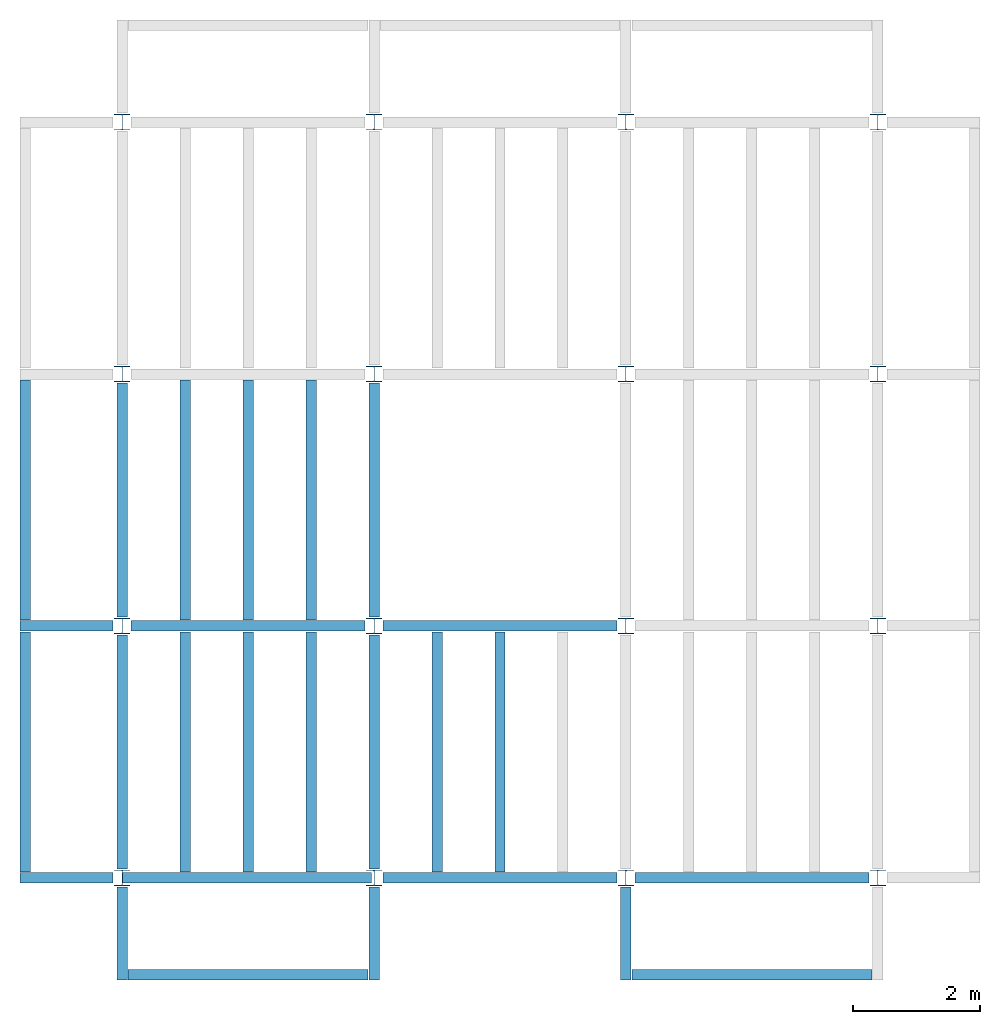
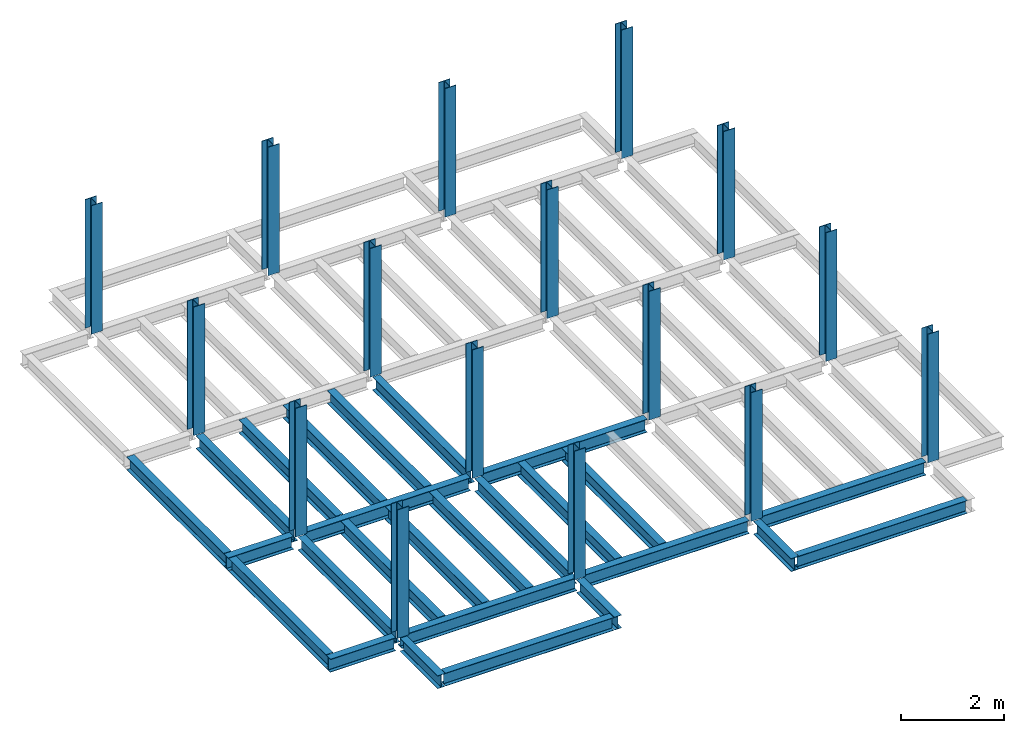
# One storey, part 1 of 3: 26 beams, 16 columns, 3 elements without a shape of their own.
"""IFC4 building model written with IfcOpenShell, lengths in feet."""

from ifc_helpers import new_model, entity, si_unit, converted_unit, derived_unit, direction, frame, origin, origin_2d, place, context, subcontext, project, spatial, line, arc, indexed_curve, i_section, outline, extrude, source, transform, mapped, material, type_object, type_shapes, element, aggregate, save


model = new_model("IFC4")

# Units and contexts
model_context = context("Model", 3, precision=0.0001, world=origin(), true_north=direction((6.123233995736766e-17, 1.0)))
plan_context = context("Plan", 3, precision=0.0001, world=origin(), true_north=direction((6.123233995736766e-17, 1.0)))
body_context = subcontext(model_context, "Body", "Model", "MODEL_VIEW")
ifc_project = project(units=[converted_unit("LENGTHUNIT", "FOOT", entity("IfcLengthMeasure", 0.3048), si_unit("LENGTHUNIT", "METRE"), dimensions=[1, 0, 0, 0, 0, 0, 0]), converted_unit("AREAUNIT", "SQUARE FOOT", entity("IfcAreaMeasure", 0.09290304), si_unit("AREAUNIT", "SQUARE_METRE"), dimensions=[2, 0, 0, 0, 0, 0, 0]), converted_unit("PLANEANGLEUNIT", "DEGREE", entity("IfcPlaneAngleMeasure", 0.017453292519943278), si_unit("PLANEANGLEUNIT", "RADIAN"), dimensions=[0, 0, 0, 0, 0, 0, 0]), converted_unit("VOLUMEUNIT", "CUBIC FOOT", entity("IfcVolumeMeasure", 0.028316846592000004), si_unit("VOLUMEUNIT", "CUBIC_METRE"), dimensions=[3, 0, 0, 0, 0, 0, 0]), si_unit("PRESSUREUNIT", "PASCAL"), derived_unit("MASSDENSITYUNIT", [(si_unit("MASSUNIT", "GRAM", prefix="KILO"), 1), (si_unit("LENGTHUNIT", "METRE"), -3)]), derived_unit("VAPORPERMEABILITYUNIT", [(si_unit("LENGTHUNIT", "METRE"), -1), (si_unit("TIMEUNIT", "SECOND"), 1)]), derived_unit("USERDEFINED", [(si_unit("MASSUNIT", "GRAM", prefix="KILO"), 1), (si_unit("LENGTHUNIT", "METRE"), 3), (si_unit("TIMEUNIT", "SECOND"), -3), (si_unit("ELECTRICCURRENTUNIT", "AMPERE"), -2)]), derived_unit("MODULUSOFELASTICITYUNIT", [(si_unit("MASSUNIT", "GRAM", prefix="KILO"), 1), (si_unit("LENGTHUNIT", "METRE"), -1), (si_unit("TIMEUNIT", "SECOND"), -2)]), derived_unit("THERMALEXPANSIONCOEFFICIENTUNIT", [(si_unit("THERMODYNAMICTEMPERATUREUNIT", "KELVIN"), -1)]), derived_unit("SPECIFICHEATCAPACITYUNIT", [(si_unit("TIMEUNIT", "SECOND"), -2), (si_unit("THERMODYNAMICTEMPERATUREUNIT", "KELVIN"), -1), (si_unit("LENGTHUNIT", "METRE"), 2)]), derived_unit("THERMALCONDUCTANCEUNIT", [(si_unit("MASSUNIT", "GRAM", prefix="KILO"), 1), (si_unit("TIMEUNIT", "SECOND"), -3), (si_unit("THERMODYNAMICTEMPERATUREUNIT", "KELVIN"), -1), (si_unit("LENGTHUNIT", "METRE"), 1)])], contexts=[model_context, plan_context])

# Site, building, storey
site_placement = place(None, origin())
site = spatial("IfcSite", under=ifc_project, at=site_placement, CompositionType="ELEMENT")
building_placement = place(site_placement, origin())
building = spatial("IfcBuilding", under=site, at=building_placement, CompositionType="ELEMENT")
storey_placement = place(building_placement, frame((0.0, 0.0, 119.875)))
storey = spatial("IfcBuildingStorey", under=building, at=storey_placement, Name="STR 13", CompositionType="ELEMENT", Elevation=119.875)

# Columns
ifc_material = material(Name="Steel ASTM A992", Category="Metal")
column_type = type_object("IfcColumnType", Name="W10X49", PredefinedType="COLUMN", material=ifc_material)
shared_shape_1 = source(origin(), body_context, "Body", "SweptSolid", [
    extrude(outline(indexed_curve([(-0.41666666666666663, -0.4166666666666676), (0.41666666666666663, -0.4166666666666676), (0.41666666666666663, -0.3699999999999996), (0.055833333333333846, -0.3699999999999996), (0.02637055078389421, -0.35779611588277277), (0.014166666666666636, -0.32833333333333287), (0.01416666666666665, 0.32833333333333303), (0.026370550783893467, 0.3577961158827727), (0.05583333333333332, 0.3700000000000003), (0.41666666666666663, 0.3700000000000003), (0.41666666666666663, 0.4166666666666656), (-0.41666666666666663, 0.4166666666666656), (-0.41666666666666663, 0.3700000000000003), (-0.05583333333333365, 0.3700000000000003), (-0.02637055078389416, 0.3577961158827734), (-0.014166666666666685, 0.32833333333333387), (-0.014166666666666685, -0.32833333333333264), (-0.026370550783893578, -0.3577961158827721), (-0.055833333333333374, -0.3699999999999996), (-0.41666666666666663, -0.3699999999999996)], segments=[line(1, 2, 3, 4), arc(4, 5, 6), line(6, 7), arc(7, 8, 9), line(9, 10, 11, 12, 13, 14), arc(14, 15, 16), line(16, 17), arc(17, 18, 19), line(19, 20, 1)], self_intersect=False)), frame((0.0, 0.0, 119.875), z_axis=(0.0, 0.0, 1.0), x_axis=(-1.0, 0.0, 0.0)), (0.0, 0.0, 1.0), 10.0),
])
type_shapes(column_type, [shared_shape_1])
for number, where, z_axis, x_axis, name in (
    (1, (0.0, 0.0, -119.875), (0.0, 0.0, 1.0), (-1.0, 0.0, 0.0), "W10X49"),
    (2, (0.0, 13.0, -119.875), (0.0, 0.0, 1.0), (-1.0, 0.0, 0.0), "W10X49"),
    (3, (0.0, 26.0, -119.875), (0.0, 0.0, 1.0), (-1.0, 0.0, 0.0), "W10X49"),
    (4, (0.0, 39.0, -119.875), (0.0, 0.0, 1.0), (-1.0, 0.0, 0.0), "W10X49"),
    (5, (13.0, 0.0, -119.875), (0.0, 0.0, 1.0), (-1.0, 0.0, 0.0), "W10X49"),
    (6, (13.0, 13.0, -119.875), (0.0, 0.0, 1.0), (-1.0, 0.0, 0.0), "W10X49"),
    (7, (13.0, 26.0, -119.875), (0.0, 0.0, 1.0), (-1.0, 0.0, 0.0), "W10X49"),
    (8, (13.0, 39.0, -119.875), (0.0, 0.0, 1.0), (-1.0, 0.0, 0.0), "W10X49"),
    (9, (26.0, 0.0, -119.875), (0.0, 0.0, 1.0), (-1.0, 0.0, 0.0), "W10X49"),
    (10, (26.0, 13.0, -119.875), (0.0, 0.0, 1.0), (-1.0, 0.0, 0.0), "W10X49"),
    (11, (26.0, 26.0, -119.875), (0.0, 0.0, 1.0), (-1.0, 0.0, 0.0), "W10X49"),
    (12, (26.0, 39.0, -119.875), (0.0, 0.0, 1.0), (-1.0, 0.0, 0.0), "W10X49"),
    (13, (39.0, 0.0, -119.875), (0.0, 0.0, 1.0), (-1.0, 0.0, 0.0), "W10X49"),
    (14, (39.0, 13.0, -119.875), (0.0, 0.0, 1.0), (-1.0, 0.0, 0.0), "W10X49"),
    (15, (39.0, 26.0, -119.875), (0.0, 0.0, 1.0), (-1.0, 0.0, 0.0), "W10X49"),
    (16, (39.0, 39.0, -119.875), (0.0, 0.0, 1.0), (-1.0, 0.0, 0.0), "W10X49"),
):
    element("IfcColumn", number, at=place(storey_placement, frame(where, z_axis=z_axis, x_axis=x_axis)), inside=storey, type_object=column_type, material=ifc_material, Name=name, ObjectType="W Shapes-Column:W10X49", PredefinedType="COLUMN", context=body_context, shape_type="MappedRepresentation", body=[
        mapped(shared_shape_1, transform((0.0, 0.0, 0.0), scale=1.0)),
    ])

# Beams
beam_type_1 = type_object("IfcBeamType", Name="W12X26", PredefinedType="JOIST", material=ifc_material)
shared_shape_2 = source(origin(), body_context, "Body", "SweptSolid", [
    extrude(outline(indexed_curve([(-0.27041666666666714, -0.47666666666666574), (-0.27041666666666714, -0.5083333333333351), (0.2704166666666669, -0.5083333333333351), (0.2704166666666669, -0.47666666666666574), (0.03458333333333309, -0.47666666666666574), (0.016905663803669493, -0.46934433619632937), (0.009583333333333202, -0.4516666666666659), (0.0095833333333332, 0.45166666666666705), (0.01690566380366948, 0.4693443361963307), (0.03458333333333325, 0.4766666666666671), (0.2704166666666669, 0.4766666666666671), (0.2704166666666669, 0.5083333333333312), (-0.2704166666666655, 0.5083333333333312), (-0.2704166666666655, 0.4766666666666671), (-0.034583333333333514, 0.47666666666666707), (-0.016905663803669865, 0.46934433619633054), (-0.009583333333333737, 0.45166666666666694), (-0.009583333333333735, -0.4516666666666658), (-0.01690566380367013, -0.4693443361963295), (-0.03458333333333368, -0.47666666666666574)], segments=[line(1, 2, 3, 4, 5), arc(5, 6, 7), line(7, 8), arc(8, 9, 10), line(10, 11, 12, 13, 14, 15), arc(15, 16, 17), line(17, 18), arc(18, 19, 20), line(20, 1)], self_intersect=False)), frame((-6.103346456692914, 0.0, 0.0), z_axis=(-1.0, 0.0, 0.0), x_axis=(0.0, -1.0, 0.0)), (0.0, 0.0, -1.0), 12.083333333333323),
])
type_shapes(beam_type_1, [shared_shape_2])
beam_1_placement = place(storey_placement, frame((6.561679790026266, 13.0, -0.50833333333334)))
element("IfcBeam", 17, at=beam_1_placement, inside=storey, type_object=beam_type_1, material=ifc_material, Name="W12X26", ObjectType="W Shapes:W12X26", PredefinedType="JOIST", context=body_context, shape_type="MappedRepresentation", body=[
    mapped(shared_shape_2, transform((0.0, 0.0, 0.0), scale=1.0)),
])
for number, where, z_axis, x_axis, name in (
    (18, (0.0, 6.561679790026247, -0.50833333333334), (0.0, 0.0, 1.0), (0.0, 1.0, 0.0), "W12X26"),
    (19, (13.0, 6.561679790026204, -0.50833333333334), (0.0, 0.0, 1.0), (0.0, 1.0, 0.0), "W12X26"),
):
    element("IfcBeam", number, at=place(storey_placement, frame(where, z_axis=z_axis, x_axis=x_axis)), inside=storey, type_object=beam_type_1, material=ifc_material, Name=name, ObjectType="W Shapes:W12X26", PredefinedType="JOIST", context=body_context, shape_type="MappedRepresentation", body=[
        mapped(shared_shape_2, transform((0.0, 0.0, 0.0), scale=1.0)),
    ])
beam_type_2 = type_object("IfcBeamType", Name="W12X26", PredefinedType="JOIST", material=ifc_material)
shared_shape_3 = source(origin(), body_context, "Body", "SweptSolid", [
    extrude(outline(indexed_curve([(-0.27041666666666714, -0.47666666666666574), (-0.27041666666666714, -0.5083333333333351), (0.2704166666666669, -0.5083333333333351), (0.2704166666666669, -0.47666666666666574), (0.03458333333333309, -0.47666666666666574), (0.016905663803669493, -0.46934433619632937), (0.009583333333333202, -0.4516666666666659), (0.0095833333333332, 0.45166666666666705), (0.01690566380366948, 0.4693443361963307), (0.03458333333333325, 0.4766666666666671), (0.2704166666666669, 0.4766666666666671), (0.2704166666666669, 0.5083333333333312), (-0.2704166666666655, 0.5083333333333312), (-0.2704166666666655, 0.4766666666666671), (-0.034583333333333514, 0.47666666666666707), (-0.016905663803669865, 0.46934433619633054), (-0.009583333333333737, 0.45166666666666694), (-0.009583333333333735, -0.4516666666666658), (-0.01690566380367013, -0.4693443361963295), (-0.03458333333333368, -0.47666666666666574)], segments=[line(1, 2, 3, 4, 5), arc(5, 6, 7), line(7, 8), arc(8, 9, 10), line(10, 11, 12, 13, 14, 15), arc(15, 16, 17), line(17, 18), arc(18, 19, 20), line(20, 1)], self_intersect=False)), frame((-6.226706036745409, 0.0, 0.0), z_axis=(-1.0, 0.0, 0.0), x_axis=(0.0, -1.0, 0.0)), (0.0, 0.0, -1.0), 12.08333333333333),
])
type_shapes(beam_type_2, [shared_shape_3])
beam_2_placement = place(storey_placement, frame((19.68503937007876, 13.0, -0.50833333333334)))
element("IfcBeam", 20, at=beam_2_placement, inside=storey, type_object=beam_type_2, material=ifc_material, Name="W12X26", ObjectType="W Shapes:W12X26", PredefinedType="JOIST", context=body_context, shape_type="MappedRepresentation", body=[
    mapped(shared_shape_3, transform((0.0, 0.0, 0.0), scale=1.0)),
])
for number, where, z_axis, x_axis, name in (
    (21, (0.0, 19.68503937007874, -0.50833333333334), (0.0, 0.0, 1.0), (0.0, 1.0, 0.0), "W12X26"),
    (22, (13.0, 19.685039370078698, -0.50833333333334), (0.0, 0.0, 1.0), (0.0, 1.0, 0.0), "W12X26"),
):
    element("IfcBeam", number, at=place(storey_placement, frame(where, z_axis=z_axis, x_axis=x_axis)), inside=storey, type_object=beam_type_2, material=ifc_material, Name=name, ObjectType="W Shapes:W12X26", PredefinedType="JOIST", context=body_context, shape_type="MappedRepresentation", body=[
        mapped(shared_shape_3, transform((0.0, 0.0, 0.0), scale=1.0)),
    ])

# Assembly, beams
assembly_1_placement = place(storey_placement, origin())
assembly_1 = element("IfcElementAssembly", 23, at=assembly_1_placement, inside=storey, Name="Structural Framing System", ObjectType="Structural Beam System:Structural Framing System", AssemblyPlace="NOTDEFINED", PredefinedType="BEAM_GRID")
beam_type_3 = type_object("IfcBeamType", Name="W12X26", PredefinedType="JOIST", material=ifc_material)
shared_shape_4 = source(origin(), body_context, "Body", "SweptSolid", [
    extrude(outline(indexed_curve([(-0.27041666666666714, -0.47666666666666574), (-0.27041666666666714, -0.5083333333333351), (0.2704166666666669, -0.5083333333333351), (0.2704166666666669, -0.47666666666666574), (0.03458333333333309, -0.47666666666666574), (0.016905663803669493, -0.46934433619632937), (0.009583333333333202, -0.4516666666666659), (0.0095833333333332, 0.45166666666666705), (0.01690566380366948, 0.4693443361963307), (0.03458333333333325, 0.4766666666666671), (0.2704166666666669, 0.4766666666666671), (0.2704166666666669, 0.5083333333333312), (-0.2704166666666655, 0.5083333333333312), (-0.2704166666666655, 0.4766666666666671), (-0.034583333333333514, 0.47666666666666707), (-0.016905663803669865, 0.46934433619633054), (-0.009583333333333737, 0.45166666666666694), (-0.009583333333333735, -0.4516666666666658), (-0.01690566380367013, -0.4693443361963295), (-0.03458333333333368, -0.47666666666666574)], segments=[line(1, 2, 3, 4, 5), arc(5, 6, 7), line(7, 8), arc(8, 9, 10), line(10, 11, 12, 13, 14, 15), arc(15, 16, 17), line(17, 18), arc(18, 19, 20), line(20, 1)], self_intersect=False)), frame((-6.187916666666566, 0.0, 0.0), z_axis=(-1.0, 0.0, 0.0), x_axis=(0.0, -1.0, 0.0)), (0.0, 0.0, -1.0), 12.375833333333075),
])
type_shapes(beam_type_3, [shared_shape_4])
beam_3_placement = place(assembly_1_placement, frame((3.250000000000031, 6.499999999999844, -0.50833333333334), z_axis=(0.0, 0.0, 1.0), x_axis=(0.0, 1.0, 0.0)))
beam_3 = element("IfcBeam", 24, at=beam_3_placement, type_object=beam_type_3, material=ifc_material, Name="W12X26", ObjectType="W Shapes:W12X26", PredefinedType="JOIST", context=body_context, shape_type="MappedRepresentation", body=[
    mapped(shared_shape_4, transform((0.0, 0.0, 0.0), scale=1.0)),
])
beam_4_placement = place(assembly_1_placement, frame((6.500000000000053, 6.4999999999998455, -0.50833333333334), z_axis=(0.0, 0.0, 1.0), x_axis=(0.0, 1.0, 0.0)))
beam_4 = element("IfcBeam", 25, at=beam_4_placement, type_object=beam_type_3, material=ifc_material, Name="W12X26", ObjectType="W Shapes:W12X26", PredefinedType="JOIST", context=body_context, shape_type="MappedRepresentation", body=[
    mapped(shared_shape_4, transform((0.0, 0.0, 0.0), scale=1.0)),
])
beam_5_placement = place(assembly_1_placement, frame((9.750000000000075, 6.499999999999844, -0.50833333333334), z_axis=(0.0, 0.0, 1.0), x_axis=(0.0, 1.0, 0.0)))
beam_5 = element("IfcBeam", 26, at=beam_5_placement, type_object=beam_type_3, material=ifc_material, Name="W12X26", ObjectType="W Shapes:W12X26", PredefinedType="JOIST", context=body_context, shape_type="MappedRepresentation", body=[
    mapped(shared_shape_4, transform((0.0, 0.0, 0.0), scale=1.0)),
])
aggregate(assembly_1, [beam_3, beam_4, beam_5])

assembly_2_placement = place(storey_placement, origin())
assembly_2 = element("IfcElementAssembly", 27, at=assembly_2_placement, inside=storey, Name="Structural Framing System", ObjectType="Structural Beam System:Structural Framing System", AssemblyPlace="NOTDEFINED", PredefinedType="BEAM_GRID")
beam_6_placement = place(assembly_2_placement, frame((3.2500000000000515, 19.49999999999968, -0.50833333333334), z_axis=(0.0, 0.0, 1.0), x_axis=(0.0, 1.0, 0.0)))
beam_6 = element("IfcBeam", 28, at=beam_6_placement, type_object=beam_type_3, material=ifc_material, Name="W12X26", ObjectType="W Shapes:W12X26", PredefinedType="JOIST", context=body_context, shape_type="MappedRepresentation", body=[
    mapped(shared_shape_4, transform((0.0, 0.0, 0.0), scale=1.0)),
])
beam_7_placement = place(assembly_2_placement, frame((6.500000000000073, 19.499999999999666, -0.50833333333334), z_axis=(0.0, 0.0, 1.0), x_axis=(0.0, 1.0, 0.0)))
beam_7 = element("IfcBeam", 29, at=beam_7_placement, type_object=beam_type_3, material=ifc_material, Name="W12X26", ObjectType="W Shapes:W12X26", PredefinedType="JOIST", context=body_context, shape_type="MappedRepresentation", body=[
    mapped(shared_shape_4, transform((0.0, 0.0, 0.0), scale=1.0)),
])
beam_8_placement = place(assembly_2_placement, frame((9.750000000000094, 19.49999999999966, -0.50833333333334), z_axis=(0.0, 0.0, 1.0), x_axis=(0.0, 1.0, 0.0)))
beam_8 = element("IfcBeam", 30, at=beam_8_placement, type_object=beam_type_3, material=ifc_material, Name="W12X26", ObjectType="W Shapes:W12X26", PredefinedType="JOIST", context=body_context, shape_type="MappedRepresentation", body=[
    mapped(shared_shape_4, transform((0.0, 0.0, 0.0), scale=1.0)),
])
aggregate(assembly_2, [beam_6, beam_7, beam_8])

assembly_3_placement = place(storey_placement, origin())
assembly_3 = element("IfcElementAssembly", 31, at=assembly_3_placement, inside=storey, Name="Structural Framing System", ObjectType="Structural Beam System:Structural Framing System", AssemblyPlace="NOTDEFINED", PredefinedType="BEAM_GRID")
beam_9_placement = place(assembly_3_placement, frame((16.250000000000092, 6.4999999999998, -0.50833333333334), z_axis=(0.0, 0.0, 1.0), x_axis=(0.0, 1.0, 0.0)))
beam_9 = element("IfcBeam", 32, at=beam_9_placement, type_object=beam_type_3, material=ifc_material, Name="W12X26", ObjectType="W Shapes:W12X26", PredefinedType="JOIST", context=body_context, shape_type="MappedRepresentation", body=[
    mapped(shared_shape_4, transform((0.0, 0.0, 0.0), scale=1.0)),
])
beam_10_placement = place(assembly_3_placement, frame((19.5000000000001, 6.4999999999998, -0.50833333333334), z_axis=(0.0, 0.0, 1.0), x_axis=(0.0, 1.0, 0.0)))
beam_10 = element("IfcBeam", 33, at=beam_10_placement, type_object=beam_type_3, material=ifc_material, Name="W12X26", ObjectType="W Shapes:W12X26", PredefinedType="JOIST", context=body_context, shape_type="MappedRepresentation", body=[
    mapped(shared_shape_4, transform((0.0, 0.0, 0.0), scale=1.0)),
])
aggregate(assembly_3, [beam_9, beam_10])

# Beams
for number, where, z_axis, x_axis, name in (
    (34, (-5.0, 6.499999999999858, -0.50833333333334), (0.0, 0.0, 1.0), (0.0, -1.0, 0.0), "W12X26"),
    (35, (-5.0, 19.499999999999705, -0.50833333333334), (0.0, 0.0, 1.0), (0.0, 1.0, 0.0), "W12X26"),
):
    element("IfcBeam", number, at=place(storey_placement, frame(where, z_axis=z_axis, x_axis=x_axis)), inside=storey, type_object=beam_type_3, material=ifc_material, Name=name, ObjectType="W Shapes:W12X26", PredefinedType="JOIST", context=body_context, shape_type="MappedRepresentation", body=[
        mapped(shared_shape_4, transform((0.0, 0.0, 0.0), scale=1.0)),
    ])
beam_type_4 = type_object("IfcBeamType", Name="W12X26", PredefinedType="JOIST", material=ifc_material)
shared_shape_5 = source(origin(), body_context, "Body", "SweptSolid", [
    extrude(outline(indexed_curve([(-0.27041666666666714, -0.47666666666666574), (-0.27041666666666714, -0.5083333333333351), (0.2704166666666669, -0.5083333333333351), (0.2704166666666669, -0.47666666666666574), (0.03458333333333309, -0.47666666666666574), (0.016905663803669493, -0.46934433619632937), (0.009583333333333202, -0.4516666666666659), (0.0095833333333332, 0.45166666666666705), (0.01690566380366948, 0.4693443361963307), (0.03458333333333325, 0.4766666666666671), (0.2704166666666669, 0.4766666666666671), (0.2704166666666669, 0.5083333333333312), (-0.2704166666666655, 0.5083333333333312), (-0.2704166666666655, 0.4766666666666671), (-0.034583333333333514, 0.47666666666666707), (-0.016905663803669865, 0.46934433619633054), (-0.009583333333333737, 0.45166666666666694), (-0.009583333333333735, -0.4516666666666658), (-0.01690566380367013, -0.4693443361963295), (-0.03458333333333368, -0.47666666666666574)], segments=[line(1, 2, 3, 4, 5), arc(5, 6, 7), line(7, 8), arc(8, 9, 10), line(10, 11, 12, 13, 14, 15), arc(15, 16, 17), line(17, 18), arc(18, 19, 20), line(20, 1)], self_intersect=False)), frame((-6.165026246719308, 0.0, 0.0), z_axis=(-1.0, 0.0, 0.0), x_axis=(0.0, -1.0, 0.0)), (0.0, 0.0, -1.0), 12.08333333333334),
])
type_shapes(beam_type_4, [shared_shape_5])
beam_11_placement = place(storey_placement, frame((32.623359580052536, 0.0, -0.50833333333334)))
element("IfcBeam", 36, at=beam_11_placement, inside=storey, type_object=beam_type_4, material=ifc_material, Name="W12X26", ObjectType="W Shapes:W12X26", PredefinedType="JOIST", context=body_context, shape_type="MappedRepresentation", body=[
    mapped(shared_shape_5, transform((0.0, 0.0, 0.0), scale=1.0)),
])
beam_type_5 = type_object("IfcBeamType", Name="W12X26", PredefinedType="JOIST", material=ifc_material)
shared_shape_6 = source(origin(), body_context, "Body", "SweptSolid", [
    extrude(outline(indexed_curve([(-0.27041666666666714, -0.47666666666666574), (-0.27041666666666714, -0.5083333333333351), (0.2704166666666669, -0.5083333333333351), (0.2704166666666669, -0.47666666666666574), (0.03458333333333309, -0.47666666666666574), (0.016905663803669493, -0.46934433619632937), (0.009583333333333202, -0.4516666666666659), (0.0095833333333332, 0.45166666666666705), (0.01690566380366948, 0.4693443361963307), (0.03458333333333325, 0.4766666666666671), (0.2704166666666669, 0.4766666666666671), (0.2704166666666669, 0.5083333333333312), (-0.2704166666666655, 0.5083333333333312), (-0.2704166666666655, 0.4766666666666671), (-0.034583333333333514, 0.47666666666666707), (-0.016905663803669865, 0.46934433619633054), (-0.009583333333333737, 0.45166666666666694), (-0.009583333333333735, -0.4516666666666658), (-0.01690566380367013, -0.4693443361963295), (-0.03458333333333368, -0.47666666666666574)], segments=[line(1, 2, 3, 4, 5), arc(5, 6, 7), line(7, 8), arc(8, 9, 10), line(10, 11, 12, 13, 14, 15), arc(15, 16, 17), line(17, 18), arc(18, 19, 20), line(20, 1)], self_intersect=False)), frame((-6.103346456692852, 0.0, 0.0), z_axis=(-1.0, 0.0, 0.0), x_axis=(0.0, -1.0, 0.0)), (0.0, 0.0, -1.0), 12.083333333333334),
])
type_shapes(beam_type_5, [shared_shape_6])
beam_12_placement = place(storey_placement, frame((19.56167979002627, 0.0, -0.50833333333334)))
element("IfcBeam", 37, at=beam_12_placement, inside=storey, type_object=beam_type_5, material=ifc_material, Name="W12X26", ObjectType="W Shapes:W12X26", PredefinedType="JOIST", context=body_context, shape_type="MappedRepresentation", body=[
    mapped(shared_shape_6, transform((0.0, 0.0, 0.0), scale=1.0)),
])
beam_type_6 = type_object("IfcBeamType", Name="W12X26", PredefinedType="JOIST", material=ifc_material)
shared_shape_7 = source(origin(), body_context, "Body", "SweptSolid", [
    extrude(outline(indexed_curve([(0.47666666666666574, -0.2704166666666672), (0.5083333333333351, -0.2704166666666672), (0.5083333333333351, 0.27041666666666686), (0.47666666666666574, 0.27041666666666686), (0.47666666666666574, 0.03458333333333307), (0.46934433619632937, 0.016905663803669473), (0.4516666666666659, 0.00958333333333318), (-0.45166666666666705, 0.00958333333333318), (-0.4693443361963307, 0.01690566380366946), (-0.4766666666666671, 0.03458333333333323), (-0.4766666666666671, 0.27041666666666686), (-0.5083333333333312, 0.27041666666666686), (-0.5083333333333312, -0.27041666666666553), (-0.4766666666666671, -0.27041666666666553), (-0.47666666666666707, -0.034583333333333535), (-0.46934433619633054, -0.016905663803669885), (-0.45166666666666694, -0.00958333333333376), (0.4516666666666658, -0.009583333333333756), (0.4693443361963295, -0.01690566380367015), (0.47666666666666574, -0.0345833333333337)], segments=[line(1, 2, 3, 4, 5), arc(5, 6, 7), line(7, 8), arc(8, 9, 10), line(10, 11, 12, 13, 14, 15), arc(15, 16, 17), line(17, 18), arc(18, 19, 20), line(20, 1)], self_intersect=False)), frame((-2.0416666666666208, 0.0, 0.0), z_axis=(1.0, 0.0, 0.0), x_axis=(0.0, 0.0, -1.0)), (0.0, 0.0, 1.0), 4.812083333333336),
])
type_shapes(beam_type_6, [shared_shape_7])
for number, where, z_axis, x_axis, name in (
    (38, (26.0, -2.500000000000538, -0.50833333333334), (0.0, 0.0, 1.0), (0.0, -1.0, 0.0), "W12X26"),
    (39, (-2.499999999999853, 13.0, -0.50833333333334), (0.0, 0.0, 1.0), (-1.0, 0.0, 0.0), "W12X26"),
    (40, (-2.4999999999998743, 0.0, -0.50833333333334), (0.0, 0.0, 1.0), (-1.0, 0.0, 0.0), "W12X26"),
):
    element("IfcBeam", number, at=place(storey_placement, frame(where, z_axis=z_axis, x_axis=x_axis)), inside=storey, type_object=beam_type_6, material=ifc_material, Name=name, ObjectType="W Shapes:W12X26", PredefinedType="JOIST", context=body_context, shape_type="MappedRepresentation", body=[
        mapped(shared_shape_7, transform((0.0, 0.0, 0.0), scale=1.0)),
    ])
beam_type_7 = type_object("IfcBeamType", Name="W12X26", PredefinedType="JOIST", material=ifc_material)
shared_shape_8 = source(origin(), body_context, "Body", "SweptSolid", [
    extrude(outline(indexed_curve([(0.47666666666666574, -0.2704166666666672), (0.5083333333333351, -0.2704166666666672), (0.5083333333333351, 0.27041666666666686), (0.47666666666666574, 0.27041666666666686), (0.47666666666666574, 0.03458333333333307), (0.46934433619632937, 0.016905663803669473), (0.4516666666666659, 0.00958333333333318), (-0.45166666666666705, 0.00958333333333318), (-0.4693443361963307, 0.01690566380366946), (-0.4766666666666671, 0.03458333333333323), (-0.4766666666666671, 0.27041666666666686), (-0.5083333333333312, 0.27041666666666686), (-0.5083333333333312, -0.27041666666666553), (-0.4766666666666671, -0.27041666666666553), (-0.47666666666666707, -0.034583333333333535), (-0.46934433619633054, -0.016905663803669885), (-0.45166666666666694, -0.00958333333333376), (0.4516666666666658, -0.009583333333333756), (0.4693443361963295, -0.01690566380367015), (0.47666666666666574, -0.0345833333333337)], segments=[line(1, 2, 3, 4, 5), arc(5, 6, 7), line(7, 8), arc(8, 9, 10), line(10, 11, 12, 13, 14, 15), arc(15, 16, 17), line(17, 18), arc(18, 19, 20), line(20, 1)], self_intersect=False)), frame((-6.187916666666685, 0.0, 0.0), z_axis=(1.0, 0.0, 0.0), x_axis=(0.0, 0.0, -1.0)), (0.0, 0.0, 1.0), 12.375833333333318),
])
type_shapes(beam_type_7, [shared_shape_8])
beam_13_placement = place(storey_placement, frame((32.50000000000002, -5.0, -0.50833333333334)))
element("IfcBeam", 41, at=beam_13_placement, inside=storey, type_object=beam_type_7, material=ifc_material, Name="W Shapes:W12X26", ObjectType="W Shapes:W12X26", PredefinedType="JOIST", context=body_context, shape_type="MappedRepresentation", body=[
    mapped(shared_shape_8, transform((0.0, 0.0, 0.0), scale=1.0)),
])
beam_type_8 = type_object("IfcBeamType", Name="W12X26", PredefinedType="JOIST", material=ifc_material)
shared_shape_9 = source(origin(), body_context, "Body", "SweptSolid", [
    extrude(outline(indexed_curve([(-0.2704166666666641, -0.50833333333334), (0.27041666666666764, -0.50833333333334), (0.27041666666666764, -0.4766666666666737), (0.03458333333333563, -0.4766666666666879), (0.01690566380367109, -0.4693443361963432), (0.009583333333335275, -0.4516666666666822), (0.009583333333335275, 0.4516666666666538), (0.01690566380367109, 0.46934433619631477), (0.03458333333333563, 0.47666666666665947), (0.2704166666666694, 0.47666666666665947), (0.27041666666666764, 0.5083333333333258), (-0.27041666666666586, 0.5083333333333258), (-0.27041666666666586, 0.47666666666665947), (-0.03458333333333208, 0.47666666666665947), (-0.016905663803667537, 0.46934433619631477), (-0.009583333333331723, 0.4516666666666538), (-0.009583333333331723, -0.4516666666666822), (-0.016905663803667537, -0.4693443361963432), (-0.03458333333333208, -0.4766666666666737), (-0.27041666666666586, -0.4766666666666737)], segments=[line(1, 2, 3, 4), arc(4, 5, 6), line(6, 7), arc(7, 8, 9), line(9, 10, 11, 12, 13, 14), arc(14, 15, 16), line(16, 17), arc(17, 18, 19), line(19, 20, 1)], self_intersect=False)), frame((13.0, -0.45833333333387627, 119.36666666666663), z_axis=(0.0, -1.0, 0.0), x_axis=(-1.0, 0.0, 0.0)), (0.0, 0.0, 1.0), 4.812083333333337),
])
type_shapes(beam_type_8, [shared_shape_9])
beam_14_placement = place(storey_placement, frame((0.0, 0.0, -119.875)))
element("IfcBeam", 42, at=beam_14_placement, inside=storey, type_object=beam_type_8, material=ifc_material, Name="W12X26", ObjectType="W Shapes:W12X26", PredefinedType="JOIST", context=body_context, shape_type="MappedRepresentation", body=[
    mapped(shared_shape_9, transform((0.0, 0.0, 0.0), scale=1.0)),
])
beam_type_9 = type_object("IfcBeamType", Name="W12X26", PredefinedType="JOIST", material=ifc_material)
shared_shape_10 = source(origin(), body_context, "Body", "SweptSolid", [
    extrude(outline(indexed_curve([(-0.50833333333334, -0.270416666666665), (-0.4766666666666737, -0.270416666666665), (-0.4766666666666879, -0.034583333333333854), (-0.4693443361963432, -0.016905663803669313), (-0.4516666666666822, -0.009583333333333499), (0.4516666666666538, -0.009583333333333499), (0.46934433619631477, -0.016905663803669313), (0.47666666666665947, -0.034583333333332966), (0.47666666666665947, -0.27041666666666675), (0.5083333333333258, -0.27041666666666675), (0.5083333333333258, 0.27041666666666675), (0.47666666666665947, 0.27041666666666764), (0.47666666666665947, 0.034583333333333854), (0.46934433619631477, 0.016905663803669313), (0.4516666666666538, 0.009583333333333499), (-0.4516666666666822, 0.009583333333333499), (-0.4693443361963432, 0.016905663803669313), (-0.4766666666666737, 0.034583333333332966), (-0.4766666666666737, 0.27041666666666675), (-0.50833333333334, 0.27041666666666764)], segments=[line(1, 2, 3), arc(3, 4, 5), line(5, 6), arc(6, 7, 8), line(8, 9, 10, 11, 12, 13), arc(13, 14, 15), line(15, 16), arc(16, 17, 18), line(18, 19, 20, 1)], self_intersect=False)), frame((0.3120833333333186, -5.0, 119.36666666666663), z_axis=(1.0, 0.0, 0.0), x_axis=(0.0, 0.0, -1.0)), (0.0, 0.0, 1.0), 12.37583333333332),
])
type_shapes(beam_type_9, [shared_shape_10])
beam_15_placement = place(storey_placement, frame((0.0, 0.0, -119.875)))
element("IfcBeam", 43, at=beam_15_placement, inside=storey, type_object=beam_type_9, material=ifc_material, Name="W Shapes:W12X26", ObjectType="W Shapes:W12X26", PredefinedType="JOIST", context=body_context, shape_type="MappedRepresentation", body=[
    mapped(shared_shape_10, transform((0.0, 0.0, 0.0), scale=1.0)),
])
beam_type_10 = type_object("IfcBeamType", Name="W12X26", PredefinedType="JOIST", material=ifc_material)
shared_shape_11 = source(origin(), body_context, "Body", "SweptSolid", [
    extrude(outline(indexed_curve([(-0.27041666666666686, -0.50833333333334), (0.27041666666666553, -0.50833333333334), (0.27041666666666553, -0.4766666666666737), (0.03458333333333355, -0.4766666666666879), (0.016905663803669275, -0.4693443361963432), (0.009583333333333723, -0.4516666666666822), (0.009583333333333218, 0.4516666666666538), (0.01690566380366942, 0.46934433619631477), (0.034583333333333716, 0.47666666666665947), (0.2704166666666672, 0.47666666666665947), (0.2704166666666672, 0.5083333333333258), (-0.27041666666666686, 0.5083333333333258), (-0.27041666666666686, 0.47666666666665947), (-0.03458333333333308, 0.47666666666665947), (-0.01690566380366875, 0.46934433619631477), (-0.009583333333333164, 0.4516666666666538), (-0.009583333333332694, -0.4516666666666822), (-0.01690566380366881, -0.4693443361963432), (-0.03458333333333319, -0.4766666666666737), (-0.27041666666666686, -0.4766666666666737)], segments=[line(1, 2, 3, 4), arc(4, 5, 6), line(6, 7), arc(7, 8, 9), line(9, 10, 11, 12, 13, 14), arc(14, 15, 16), line(16, 17), arc(17, 18, 19), line(19, 20, 1)], self_intersect=False)), frame((0.0, -0.45833333333383364, 119.36666666666663), z_axis=(0.0, -1.0, 0.0), x_axis=(-1.0, 0.0, 0.0)), (0.0, 0.0, 1.0), 4.812083333333337),
])
type_shapes(beam_type_10, [shared_shape_11])
beam_16_placement = place(storey_placement, frame((0.0, 0.0, -119.875)))
element("IfcBeam", 44, at=beam_16_placement, inside=storey, type_object=beam_type_10, material=ifc_material, Name="W12X26", ObjectType="W Shapes:W12X26", PredefinedType="JOIST", context=body_context, shape_type="MappedRepresentation", body=[
    mapped(shared_shape_11, transform((0.0, 0.0, 0.0), scale=1.0)),
])
beam_type_11 = type_object("IfcBeamType", Name="W12X26", PredefinedType="BEAM")
beam_17_placement = place(storey_placement, frame((0.0, 0.0, -0.50833333333334), z_axis=(-1.0, 0.0, 0.0), x_axis=(0.0, -1.0, 0.0)))
element("IfcBeam", 45, at=beam_17_placement, inside=storey, type_object=beam_type_11, material=ifc_material, Name="W12X26", ObjectType="W12X26", context=model_context, shape_type="SweptSolid", body=[
    extrude(i_section(OverallWidth=0.5408333333333333, OverallDepth=1.0166666666666666, WebThickness=0.019166666666666665, FlangeThickness=0.03166666666666666, FilletRadius=0.024999999999999998, at=origin_2d()), origin(), (0.0, 0.0, -1.0), 12.876640419947506),
])

save(model, "model.ifc")
